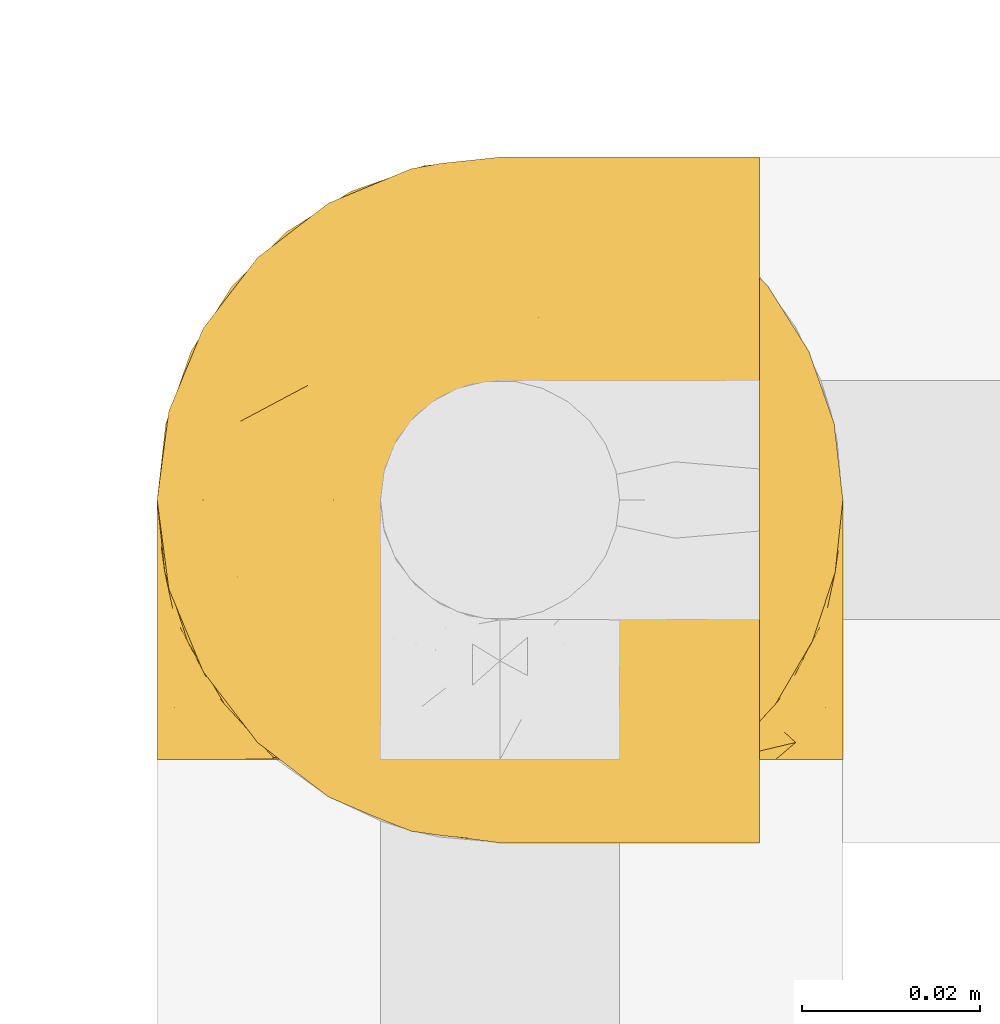
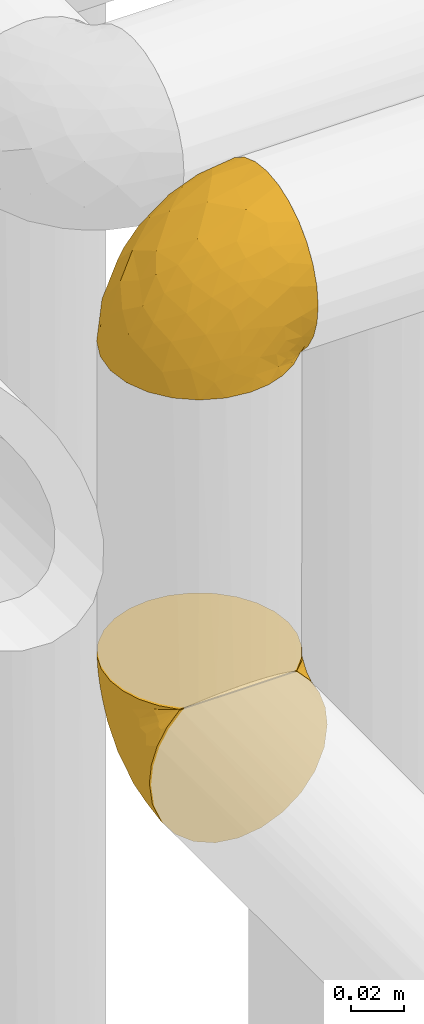
# One storey, part 295 of 827: 2 coverings.
"""IFC2X3 building model written with IfcOpenShell, lengths in millimetres."""

from ifc_helpers import new_model, entity, si_unit, converted_unit, derived_unit, direction, frame, origin, place, context, subcontext, project, spatial, faceted_brep, element, save


model = new_model("IFC2X3")

# Units and contexts
model_context = context("Model", 3, precision=0.01, world=origin(), true_north=direction((6.12303176911189e-17, 1.0)))
body_context = subcontext(model_context, "Body", "Model", "MODEL_VIEW")
ifc_project = project(units=[si_unit("LENGTHUNIT", "METRE", prefix="MILLI"), si_unit("AREAUNIT", "SQUARE_METRE"), si_unit("VOLUMEUNIT", "CUBIC_METRE"), converted_unit("PLANEANGLEUNIT", "DEGREE", entity("IfcRatioMeasure", 0.0174532925199433), si_unit("PLANEANGLEUNIT", "RADIAN"), dimensions=[0, 0, 0, 0, 0, 0, 0]), si_unit("MASSUNIT", "GRAM", prefix="KILO"), derived_unit("MASSDENSITYUNIT", [(si_unit("MASSUNIT", "GRAM", prefix="KILO"), 1), (si_unit("LENGTHUNIT", "METRE"), -3)]), derived_unit("MOMENTOFINERTIAUNIT", [(si_unit("LENGTHUNIT", "METRE"), 4)]), si_unit("TIMEUNIT", "SECOND"), si_unit("FREQUENCYUNIT", "HERTZ"), si_unit("THERMODYNAMICTEMPERATUREUNIT", "DEGREE_CELSIUS"), derived_unit("THERMALTRANSMITTANCEUNIT", [(si_unit("MASSUNIT", "GRAM", prefix="KILO"), 1), (si_unit("THERMODYNAMICTEMPERATUREUNIT", "KELVIN"), -1), (si_unit("TIMEUNIT", "SECOND"), -3)]), derived_unit("VOLUMETRICFLOWRATEUNIT", [(si_unit("LENGTHUNIT", "METRE"), 3), (si_unit("TIMEUNIT", "SECOND"), -1)]), derived_unit("MASSFLOWRATEUNIT", [(si_unit("MASSUNIT", "GRAM", prefix="KILO"), 1), (si_unit("TIMEUNIT", "SECOND"), -1)]), derived_unit("ROTATIONALFREQUENCYUNIT", [(si_unit("TIMEUNIT", "SECOND"), -1)]), si_unit("ELECTRICCURRENTUNIT", "AMPERE"), si_unit("ELECTRICVOLTAGEUNIT", "VOLT"), si_unit("POWERUNIT", "WATT"), si_unit("FORCEUNIT", "NEWTON", prefix="KILO"), si_unit("ILLUMINANCEUNIT", "LUX"), si_unit("LUMINOUSFLUXUNIT", "LUMEN"), si_unit("LUMINOUSINTENSITYUNIT", "CANDELA"), derived_unit("USERDEFINED", [(si_unit("MASSUNIT", "GRAM", prefix="KILO"), -1), (si_unit("LENGTHUNIT", "METRE"), -2), (si_unit("TIMEUNIT", "SECOND"), 3), (si_unit("LUMINOUSFLUXUNIT", "LUMEN"), 1)]), derived_unit("LINEARVELOCITYUNIT", [(si_unit("LENGTHUNIT", "METRE"), 1), (si_unit("TIMEUNIT", "SECOND"), -1)]), si_unit("PRESSUREUNIT", "PASCAL"), derived_unit("USERDEFINED", [(si_unit("LENGTHUNIT", "METRE"), -2), (si_unit("MASSUNIT", "GRAM", prefix="KILO"), 1), (si_unit("TIMEUNIT", "SECOND"), -2)]), derived_unit("LINEARFORCEUNIT", [(si_unit("MASSUNIT", "GRAM", prefix="KILO"), 1), (si_unit("LENGTHUNIT", "METRE"), 1), (si_unit("TIMEUNIT", "SECOND"), -2), (si_unit("LENGTHUNIT", "METRE"), -1)]), derived_unit("PLANARFORCEUNIT", [(si_unit("MASSUNIT", "GRAM", prefix="KILO"), 1), (si_unit("LENGTHUNIT", "METRE"), 1), (si_unit("TIMEUNIT", "SECOND"), -2), (si_unit("LENGTHUNIT", "METRE"), -2)])], contexts=[model_context])

# Site, building, storey
site_placement = place(None, origin())
site = spatial("IfcSite", under=ifc_project, at=site_placement, CompositionType="ELEMENT")
building_placement = place(site_placement, origin())
building = spatial("IfcBuilding", under=site, at=building_placement, CompositionType="ELEMENT")
storey_placement = place(building_placement, frame((0.0, 0.0, 28200.0)))
storey = spatial("IfcBuildingStorey", under=building, at=storey_placement, Name="08", CompositionType="ELEMENT", Elevation=28200.0)

# Coverings
covering_1_placement = place(storey_placement, frame((34787.8, 15358.9, 2759.95)))
element("IfcCovering", 1, at=covering_1_placement, inside=storey, Name=":ADSK_", ObjectType=":ADSK_", PredefinedType="INSULATION", context=body_context, shape_type="Brep", body=[
    faceted_brep([(74.68, 47.38, 69.15), (70.1, 54.67, 69.15), (64.01, 60.76, 69.15), (56.72, 65.34, 69.15), (48.6, 68.18, 69.15), (40.05, 69.15, 69.15), (31.49, 68.18, 69.15), (23.36, 65.33, 69.15), (16.07, 60.75, 69.15), (9.98, 54.66, 69.15), (5.4, 47.37, 69.15), (2.56, 39.25, 69.15), (1.6, 30.7, 69.15), (2.46, 22.59, 69.15), (5.01, 14.86, 69.15), (9.13, 7.84, 69.15), (14.62, 1.85, 69.15), (16.82, 1.85, 69.15), (18.56, 1.85, 69.15), (20.52, 1.85, 69.15), (22.49, 1.85, 69.15), (24.46, 1.85, 69.15), (26.42, 1.85, 69.15), (28.39, 1.85, 69.15), (30.36, 1.85, 69.15), (32.55, 1.85, 69.15), (34.75, 1.85, 69.15), (36.94, 1.85, 69.15), (39.13, 1.85, 69.15), (41.33, 1.85, 69.15), (43.52, 1.85, 69.15), (45.72, 1.85, 69.15), (47.91, 1.85, 69.15), (50.11, 1.85, 69.15), (52.3, 1.85, 69.15), (54.49, 1.85, 69.15), (56.69, 1.85, 69.15), (58.88, 1.85, 69.15), (61.08, 1.85, 69.15), (63.27, 1.85, 69.15), (65.47, 1.85, 69.15), (70.97, 7.85, 69.15), (75.09, 14.88, 69.15), (77.64, 22.61, 69.15), (78.5, 30.7, 69.15), (77.53, 39.26, 69.15), (14.62, 1.6, 68.89), (9.12, 1.6, 62.89), (5.0, 1.6, 55.87), (2.46, 1.6, 48.14), (1.6, 1.6, 40.05), (2.91, 1.6, 30.09), (6.75, 1.6, 20.82), (12.86, 1.6, 12.86), (20.82, 1.6, 6.75), (30.09, 1.6, 2.91), (40.05, 1.6, 1.6), (50.0, 1.6, 2.91), (59.27, 1.6, 6.75), (67.23, 1.6, 12.86), (73.34, 1.6, 20.82), (77.19, 1.6, 30.09), (78.5, 1.6, 40.05), (77.63, 1.6, 48.14), (75.09, 1.6, 55.87), (70.97, 1.6, 62.89), (65.47, 1.6, 68.89), (63.27, 1.6, 68.89), (62.29, 1.6, 68.89), (60.7, 1.6, 68.89), (59.11, 1.6, 68.89), (57.52, 1.6, 68.89), (55.93, 1.6, 68.89), (54.34, 1.6, 68.89), (52.76, 1.6, 68.89), (51.17, 1.6, 68.89), (49.58, 1.6, 68.89), (47.99, 1.6, 68.89), (46.4, 1.6, 68.89), (44.81, 1.6, 68.89), (43.22, 1.6, 68.89), (41.63, 1.6, 68.89), (40.05, 1.6, 68.89), (38.46, 1.6, 68.89), (36.87, 1.6, 68.89), (35.28, 1.6, 68.89), (33.69, 1.6, 68.89), (32.1, 1.6, 68.89), (30.51, 1.6, 68.89), (28.92, 1.6, 68.89), (27.33, 1.6, 68.89), (25.37, 1.6, 68.89), (23.4, 1.6, 68.89), (21.21, 1.6, 68.89), (19.01, 1.6, 68.89), (16.82, 1.6, 68.89), (42.32, 1.78, 68.97), (44.02, 1.77, 68.96), (47.13, 1.78, 68.97), (48.74, 1.77, 68.97), (23.57, 1.79, 68.98), (25.13, 1.78, 68.97), (61.34, 1.76, 68.96), (22.02, 1.77, 68.96), (29.72, 1.77, 68.96), (56.73, 1.76, 68.96), (55.14, 1.77, 68.96), (37.66, 1.77, 68.96), (64.12, 1.8, 69.0), (28.13, 1.76, 68.96), (26.62, 1.77, 68.96), (31.46, 1.78, 68.97), (16.16, 1.77, 68.96), (39.16, 1.77, 68.96), (50.37, 1.76, 68.96), (17.69, 1.77, 68.97), (19.17, 1.78, 68.97), (62.78, 1.77, 68.97), (58.35, 1.77, 68.96), (45.53, 1.77, 68.96), (59.91, 1.78, 68.97), (65.47, 1.77, 68.97), (65.47, 1.8, 69.02), (65.47, 1.82, 69.08), (14.62, 1.77, 68.97), (14.62, 1.72, 68.94), (14.62, 1.66, 68.92), (20.59, 1.76, 68.96), (32.99, 1.77, 68.96), (34.48, 1.76, 68.95), (51.91, 1.77, 68.96), (65.47, 1.66, 68.92), (65.47, 1.72, 68.94), (53.48, 1.78, 68.98), (14.62, 1.82, 69.08), (14.62, 1.8, 69.02), (40.77, 1.77, 68.96), (35.97, 1.78, 68.97), (7.84, 3.72, 61.33), (3.53, 7.41, 53.1), (8.32, 6.13, 63.33), (1.6, 21.47, 49.27), (2.19, 19.34, 55.53), (1.6, 26.8, 54.6), (1.6, 8.87, 41.99), (4.57, 9.2, 57.07), (3.96, 12.79, 57.95), (2.28, 14.62, 51.56), (1.6, 7.34, 41.58), (7.69, 5.33, 61.7), (3.53, 17.64, 63.33), (8.32, 7.7, 65.0), (7.84, 9.41, 67.02), (1.6, 28.75, 61.87), (1.6, 16.15, 43.94), (4.34, 14.14, 61.21), (1.6, 29.16, 63.4), (29.63, 57.02, 33.11), (27.34, 64.92, 52.82), (40.05, 64.0, 43.3), (2.39, 11.92, 33.73), (2.43, 19.16, 36.52), (9.07, 28.65, 24.87), (16.64, 24.62, 14.17), (9.54, 15.19, 18.43), (4.52, 18.36, 28.67), (4.52, 9.2, 26.0), (7.49, 46.98, 49.25), (7.49, 50.24, 59.72), (12.85, 56.1, 55.1), (2.35, 28.97, 44.72), (22.66, 54.46, 34.15), (32.9, 21.34, 5.25), (25.33, 18.4, 6.75), (40.05, 66.44, 55.54), (16.64, 12.07, 10.47), (19.99, 45.49, 25.49), (16.37, 50.57, 35.53), (3.26, 36.04, 48.22), (3.75, 42.07, 58.71), (19.58, 62.12, 57.42), (7.5, 37.37, 34.84), (4.04, 29.39, 36.87), (13.94, 53.59, 45.01), (19.58, 58.06, 44.4), (28.21, 49.27, 23.96), (24.75, 29.63, 11.2), (31.42, 33.21, 10.56), (26.2, 40.1, 16.81), (33.36, 44.08, 17.38), (40.05, 49.36, 21.38), (40.05, 56.68, 32.34), (40.05, 15.2, 4.3), (16.14, 35.57, 20.65), (12.85, 41.7, 29.66), (10.47, 46.4, 39.6), (6.49, 41.41, 42.55), (40.05, 27.45, 6.74), (40.05, 38.4, 14.06), (75.57, 12.99, 26.84), (47.37, 21.33, 5.28), (52.91, 42.89, 18.52), (50.46, 57.04, 33.13), (67.23, 56.11, 55.1), (60.5, 62.13, 57.43), (70.55, 21.89, 20.72), (63.45, 16.62, 11.46), (62.61, 32.9, 17.69), (72.6, 46.99, 49.26), (72.6, 50.25, 59.73), (76.34, 42.08, 58.71), (59.34, 49.91, 29.72), (77.76, 15.6, 35.35), (78.5, 16.15, 43.94), (78.5, 8.87, 41.99), (78.5, 29.16, 63.4), (53.16, 13.16, 4.93), (70.55, 10.83, 17.46), (48.88, 33.8, 10.94), (54.76, 25.02, 8.92), (52.74, 64.92, 52.83), (71.93, 32.83, 29.34), (75.79, 20.56, 30.26), (60.5, 58.07, 44.4), (77.86, 21.46, 39.06), (77.64, 28.1, 43.06), (78.5, 26.8, 54.6), (78.5, 21.47, 49.27), (67.23, 51.29, 42.69), (76.82, 36.04, 48.2), (78.5, 28.75, 61.87), (77.8, 8.45, 33.44), (67.23, 41.73, 29.67), (73.2, 39.27, 38.5), (67.66, 33.56, 23.35), (75.99, 27.29, 34.97), (76.57, 7.41, 53.1), (73.21, 3.51, 59.68), (71.93, 4.68, 62.19), (71.07, 5.52, 64.11), (75.09, 8.75, 57.97), (76.13, 12.79, 57.95), (76.57, 17.65, 63.33), (77.69, 13.9, 51.77), (72.26, 9.42, 67.02), (71.77, 7.68, 64.98), (77.9, 19.33, 55.53), (75.75, 14.13, 61.22)], [[[0, 1, 2, 3, 4, 5, 6, 7, 8, 9, 10, 11, 12, 13, 14, 15, 16, 17, 18, 19, 20, 21, 22, 23, 24, 25, 26, 27, 28, 29, 30, 31, 32, 33, 34, 35, 36, 37, 38, 39, 40, 41, 42, 43, 44, 45]], [[46, 47, 48, 49, 50, 51, 52, 53, 54, 55, 56, 57, 58, 59, 60, 61, 62, 63, 64, 65, 66, 67, 68, 69, 70, 71, 72, 73, 74, 75, 76, 77, 78, 79, 80, 81, 82, 83, 84, 85, 86, 87, 88, 89, 90, 91, 92, 93, 94, 95]], [[96, 97, 30]], [[98, 77, 99]], [[100, 101, 21]], [[69, 68, 102]], [[20, 19, 103]], [[24, 23, 104]], [[20, 103, 100]], [[72, 105, 106]], [[84, 83, 107]], [[89, 88, 104]], [[108, 67, 66]], [[109, 110, 90]], [[111, 25, 24]], [[112, 17, 16]], [[82, 113, 83]], [[109, 23, 22]], [[114, 76, 75]], [[105, 36, 106]], [[104, 111, 24]], [[18, 115, 116]], [[97, 96, 80]], [[67, 108, 117]], [[105, 71, 118]], [[31, 97, 119]], [[102, 120, 69]], [[108, 121, 122, 123, 40]], [[112, 95, 115]], [[17, 115, 18]], [[94, 116, 115]], [[117, 68, 67]], [[38, 117, 39]], [[112, 124, 125, 126, 46]], [[17, 112, 115]], [[70, 120, 118]], [[39, 117, 108]], [[120, 38, 37]], [[120, 37, 118]], [[120, 70, 69]], [[116, 94, 127]], [[128, 86, 129]], [[117, 38, 102]], [[74, 130, 75]], [[99, 33, 32]], [[115, 95, 94]], [[39, 108, 40]], [[108, 66, 131, 132, 121]], [[105, 72, 71]], [[118, 37, 36]], [[71, 70, 118]], [[35, 106, 36]], [[36, 105, 118]], [[35, 133, 106]], [[74, 73, 133]], [[106, 133, 73]], [[99, 114, 33]], [[133, 35, 34]], [[73, 72, 106]], [[95, 112, 46]], [[112, 16, 134, 135, 124]], [[130, 114, 75]], [[99, 76, 114]], [[114, 130, 33]], [[34, 33, 130]], [[78, 77, 98]], [[98, 119, 78]], [[130, 133, 34]], [[133, 130, 74]], [[79, 97, 80]], [[98, 99, 32]], [[98, 32, 31]], [[77, 76, 99]], [[97, 79, 119]], [[136, 96, 29]], [[30, 97, 31]], [[136, 29, 28]], [[81, 80, 96]], [[29, 96, 30]], [[31, 119, 98]], [[119, 79, 78]], [[96, 136, 81]], [[82, 81, 136]], [[113, 107, 83]], [[84, 107, 137]], [[107, 27, 137]], [[113, 28, 107]], [[27, 107, 28]], [[85, 84, 137]], [[137, 27, 26]], [[113, 136, 28]], [[136, 113, 82]], [[109, 89, 104]], [[86, 85, 129]], [[89, 109, 90]], [[111, 87, 128]], [[26, 129, 137]], [[88, 111, 104]], [[25, 111, 128]], [[22, 110, 109]], [[23, 109, 104]], [[110, 91, 90]], [[100, 92, 101]], [[110, 22, 101]], [[91, 110, 101]], [[116, 19, 18]], [[111, 88, 87]], [[127, 103, 19]], [[25, 128, 26]], [[86, 128, 87]], [[128, 129, 26]], [[137, 129, 85]], [[120, 102, 38]], [[117, 102, 68]], [[91, 101, 92]], [[21, 101, 22]], [[93, 92, 103]], [[100, 21, 20]], [[100, 103, 92]], [[127, 93, 103]], [[93, 127, 94]], [[116, 127, 19]], [[126, 138, 47]], [[48, 138, 139]], [[140, 125, 124]], [[141, 142, 143]], [[144, 49, 139]], [[145, 140, 146]], [[48, 139, 49]], [[139, 145, 147]], [[49, 144, 148, 50]], [[126, 125, 149]], [[14, 13, 150]], [[151, 146, 140]], [[149, 140, 145]], [[152, 151, 135]], [[152, 14, 150]], [[16, 15, 134]], [[13, 153, 150]], [[124, 151, 140]], [[141, 147, 142]], [[14, 152, 15]], [[15, 152, 134]], [[47, 46, 126]], [[139, 154, 144]], [[138, 48, 47]], [[125, 140, 149]], [[135, 134, 152]], [[146, 155, 142]], [[145, 146, 147]], [[149, 139, 138]], [[147, 141, 154]], [[147, 146, 142]], [[139, 147, 154]], [[139, 149, 145]], [[149, 138, 126]], [[155, 146, 151]], [[150, 143, 142]], [[152, 155, 151]], [[150, 142, 155]], [[13, 12, 156, 153]], [[153, 143, 150]], [[152, 150, 155]], [[151, 124, 135]], [[157, 158, 159]], [[160, 154, 161]], [[162, 163, 164]], [[165, 166, 160]], [[167, 168, 169]], [[141, 170, 161]], [[156, 12, 11]], [[158, 157, 171]], [[172, 55, 173]], [[158, 6, 174]], [[175, 54, 53]], [[52, 166, 164]], [[52, 164, 53]], [[54, 175, 173]], [[166, 52, 51]], [[176, 177, 171]], [[178, 143, 179]], [[156, 11, 179]], [[8, 7, 180]], [[169, 9, 8]], [[179, 143, 153, 156]], [[179, 11, 10]], [[168, 179, 10]], [[181, 162, 182]], [[179, 167, 178]], [[183, 184, 177]], [[183, 169, 184]], [[176, 171, 185]], [[172, 186, 187]], [[158, 7, 6]], [[159, 158, 174]], [[184, 180, 158]], [[54, 173, 55]], [[180, 169, 8]], [[188, 189, 187]], [[9, 168, 10]], [[186, 188, 187]], [[190, 157, 159, 191]], [[55, 172, 192]], [[176, 193, 194]], [[161, 170, 182]], [[162, 164, 165]], [[175, 164, 163]], [[51, 50, 148]], [[167, 195, 196]], [[178, 182, 170]], [[6, 5, 174]], [[158, 180, 7]], [[169, 180, 184]], [[169, 168, 9]], [[179, 168, 167]], [[182, 162, 165]], [[162, 194, 193]], [[161, 165, 160]], [[195, 181, 196]], [[192, 172, 197]], [[192, 56, 55]], [[189, 190, 198]], [[198, 197, 187]], [[172, 187, 197]], [[185, 189, 188]], [[198, 187, 189]], [[186, 172, 173]], [[173, 163, 186]], [[193, 186, 163]], [[176, 185, 188]], [[185, 157, 190]], [[188, 186, 193]], [[177, 176, 194]], [[188, 193, 176]], [[162, 193, 163]], [[195, 177, 194]], [[171, 177, 184]], [[181, 195, 194]], [[183, 167, 169]], [[162, 181, 194]], [[196, 182, 178]], [[158, 171, 184]], [[171, 157, 185]], [[177, 195, 183]], [[167, 183, 195]], [[182, 196, 181]], [[178, 170, 143]], [[178, 167, 196]], [[164, 175, 53]], [[173, 175, 163]], [[160, 51, 148]], [[164, 166, 165]], [[51, 160, 166]], [[160, 148, 144, 154]], [[141, 161, 154]], [[182, 165, 161]], [[190, 189, 185]], [[143, 170, 141]], [[60, 199, 61]], [[197, 200, 192]], [[201, 190, 202]], [[200, 57, 192]], [[203, 204, 2]], [[205, 206, 207]], [[208, 209, 210]], [[211, 207, 201]], [[212, 213, 214]], [[45, 215, 210]], [[216, 206, 58]], [[45, 44, 215]], [[59, 217, 60]], [[60, 217, 199]], [[0, 45, 210]], [[218, 201, 219]], [[202, 159, 220]], [[205, 221, 222]], [[223, 204, 203]], [[1, 203, 2]], [[57, 200, 216]], [[220, 3, 204]], [[220, 174, 4]], [[1, 0, 209]], [[212, 224, 213]], [[225, 226, 227]], [[228, 223, 203]], [[208, 210, 229]], [[210, 226, 229]], [[3, 220, 4]], [[58, 206, 59]], [[209, 203, 1]], [[202, 220, 223]], [[228, 203, 208]], [[202, 211, 201]], [[3, 2, 204]], [[202, 190, 191, 159]], [[210, 215, 230, 226]], [[199, 212, 231]], [[232, 233, 221]], [[233, 208, 229]], [[207, 206, 219]], [[217, 206, 205]], [[227, 224, 225]], [[233, 232, 228]], [[201, 207, 219]], [[234, 232, 221]], [[218, 219, 200]], [[202, 223, 211]], [[174, 220, 159]], [[174, 5, 4]], [[61, 231, 62]], [[220, 204, 223]], [[210, 209, 0]], [[203, 209, 208]], [[225, 233, 229]], [[224, 227, 213]], [[221, 233, 235]], [[57, 56, 192]], [[198, 218, 197]], [[200, 219, 216]], [[201, 198, 190]], [[197, 218, 200]], [[198, 201, 218]], [[206, 216, 219]], [[58, 57, 216]], [[231, 212, 214]], [[222, 212, 199]], [[228, 211, 223]], [[207, 211, 232]], [[62, 231, 214]], [[199, 231, 61]], [[233, 228, 208]], [[211, 228, 232]], [[222, 221, 235]], [[234, 205, 207]], [[206, 217, 59]], [[199, 217, 205]], [[205, 222, 199]], [[224, 222, 235]], [[222, 224, 212]], [[224, 235, 225]], [[233, 225, 235]], [[226, 225, 229]], [[205, 234, 221]], [[207, 232, 234]], [[63, 214, 236]], [[214, 213, 236]], [[214, 63, 62]], [[237, 236, 238]], [[238, 132, 131]], [[236, 237, 64]], [[239, 240, 241]], [[63, 236, 64]], [[131, 66, 65]], [[237, 131, 65]], [[242, 230, 43]], [[237, 65, 64]], [[239, 121, 132]], [[42, 242, 43]], [[241, 240, 243]], [[41, 123, 244]], [[43, 230, 215, 44]], [[244, 122, 245]], [[227, 246, 243]], [[241, 247, 245]], [[121, 239, 245]], [[41, 40, 123]], [[132, 238, 239]], [[244, 42, 41]], [[131, 237, 238]], [[240, 239, 238]], [[245, 239, 241]], [[247, 241, 246]], [[247, 244, 245]], [[238, 236, 240]], [[243, 236, 213]], [[236, 243, 240]], [[227, 226, 246]], [[243, 213, 227]], [[242, 246, 226]], [[243, 246, 241]], [[246, 242, 247]], [[244, 247, 242]], [[242, 226, 230]], [[42, 244, 242]], [[122, 244, 123]], [[122, 121, 245]]]),
])
covering_2_placement = place(storey_placement, frame((34787.8, 15349.55, 2969.3)))
element("IfcCovering", 2, at=covering_2_placement, inside=storey, Name=":ADSK_", ObjectType=":ADSK_", PredefinedType="INSULATION", context=body_context, shape_type="Brep", body=[
    faceted_brep([(69.15, 74.68, 47.38), (69.15, 70.1, 54.67), (69.15, 64.01, 60.76), (69.15, 56.72, 65.34), (69.15, 48.6, 68.18), (69.15, 40.05, 69.15), (69.15, 31.49, 68.18), (69.15, 23.36, 65.33), (69.15, 16.07, 60.75), (69.15, 9.98, 54.66), (69.15, 5.4, 47.37), (69.15, 2.56, 39.25), (69.15, 1.6, 30.7), (69.15, 2.46, 22.59), (69.15, 5.01, 14.86), (69.15, 9.13, 7.84), (69.15, 14.62, 1.85), (69.15, 16.82, 1.85), (69.15, 18.56, 1.85), (69.15, 20.52, 1.85), (69.15, 22.49, 1.85), (69.15, 24.46, 1.85), (69.15, 26.42, 1.85), (69.15, 28.39, 1.85), (69.15, 30.36, 1.85), (69.15, 32.55, 1.85), (69.15, 34.75, 1.85), (69.15, 36.94, 1.85), (69.15, 39.13, 1.85), (69.15, 41.33, 1.85), (69.15, 43.52, 1.85), (69.15, 45.72, 1.85), (69.15, 47.91, 1.85), (69.15, 50.11, 1.85), (69.15, 52.3, 1.85), (69.15, 54.49, 1.85), (69.15, 56.69, 1.85), (69.15, 58.88, 1.85), (69.15, 61.08, 1.85), (69.15, 63.27, 1.85), (69.15, 65.47, 1.85), (69.15, 70.97, 7.85), (69.15, 75.09, 14.88), (69.15, 77.64, 22.61), (69.15, 78.5, 30.7), (69.15, 77.53, 39.26), (68.89, 14.62, 1.6), (62.89, 9.12, 1.6), (55.87, 5.0, 1.6), (48.14, 2.46, 1.6), (40.05, 1.6, 1.6), (30.09, 2.91, 1.6), (20.82, 6.75, 1.6), (12.86, 12.86, 1.6), (6.75, 20.82, 1.6), (2.91, 30.09, 1.6), (1.6, 40.05, 1.6), (2.91, 50.0, 1.6), (6.75, 59.27, 1.6), (12.86, 67.23, 1.6), (20.82, 73.34, 1.6), (30.09, 77.19, 1.6), (40.05, 78.5, 1.6), (48.14, 77.63, 1.6), (55.87, 75.09, 1.6), (62.89, 70.97, 1.6), (68.89, 65.47, 1.6), (68.89, 63.27, 1.6), (68.89, 62.29, 1.6), (68.89, 60.7, 1.6), (68.89, 59.11, 1.6), (68.89, 57.52, 1.6), (68.89, 55.93, 1.6), (68.89, 54.34, 1.6), (68.89, 52.76, 1.6), (68.89, 51.17, 1.6), (68.89, 49.58, 1.6), (68.89, 47.99, 1.6), (68.89, 46.4, 1.6), (68.89, 44.81, 1.6), (68.89, 43.22, 1.6), (68.89, 41.63, 1.6), (68.89, 40.05, 1.6), (68.89, 38.46, 1.6), (68.89, 36.87, 1.6), (68.89, 35.28, 1.6), (68.89, 33.69, 1.6), (68.89, 32.1, 1.6), (68.89, 30.51, 1.6), (68.89, 28.92, 1.6), (68.89, 27.33, 1.6), (68.89, 25.37, 1.6), (68.89, 23.4, 1.6), (68.89, 21.21, 1.6), (68.89, 19.01, 1.6), (68.89, 16.82, 1.6), (68.97, 42.32, 1.78), (68.96, 44.02, 1.77), (68.97, 47.13, 1.78), (68.97, 48.74, 1.77), (68.98, 23.57, 1.79), (68.97, 25.13, 1.78), (68.96, 61.34, 1.76), (68.96, 22.02, 1.77), (68.96, 29.72, 1.77), (68.96, 56.73, 1.76), (68.96, 55.14, 1.77), (68.96, 37.66, 1.77), (69.0, 64.12, 1.8), (68.96, 28.13, 1.76), (68.96, 26.62, 1.77), (68.97, 31.46, 1.78), (68.96, 16.16, 1.77), (68.96, 39.16, 1.77), (68.96, 50.37, 1.76), (68.97, 17.69, 1.77), (68.97, 19.17, 1.78), (68.97, 62.78, 1.77), (68.96, 58.35, 1.77), (68.96, 45.53, 1.77), (68.97, 59.91, 1.78), (68.97, 65.47, 1.77), (69.02, 65.47, 1.8), (69.08, 65.47, 1.82), (68.97, 14.62, 1.77), (68.94, 14.62, 1.72), (68.92, 14.62, 1.66), (68.96, 20.59, 1.76), (68.96, 32.99, 1.77), (68.95, 34.48, 1.76), (68.96, 51.91, 1.77), (68.92, 65.47, 1.66), (68.94, 65.47, 1.72), (68.98, 53.48, 1.78), (69.08, 14.62, 1.82), (69.02, 14.62, 1.8), (68.96, 40.77, 1.77), (68.97, 35.97, 1.78), (61.33, 7.84, 3.72), (53.1, 3.53, 7.41), (63.33, 8.32, 6.13), (55.53, 2.19, 19.34), (63.33, 3.53, 17.64), (54.6, 1.6, 26.8), (41.99, 1.6, 8.87), (57.07, 4.57, 9.2), (57.95, 3.96, 12.79), (51.56, 2.28, 14.62), (41.58, 1.6, 7.34), (61.7, 7.69, 5.33), (65.0, 8.32, 7.7), (67.02, 7.84, 9.41), (61.87, 1.6, 28.75), (49.27, 1.6, 21.47), (43.94, 1.6, 16.15), (61.21, 4.34, 14.14), (63.4, 1.6, 29.16), (33.11, 29.63, 57.02), (52.82, 27.34, 64.92), (43.3, 40.05, 64.0), (33.73, 2.39, 11.92), (36.52, 2.43, 19.16), (24.87, 9.07, 28.65), (14.17, 16.64, 24.62), (18.43, 9.54, 15.19), (28.67, 4.52, 18.36), (26.0, 4.52, 9.2), (49.25, 7.49, 46.98), (59.72, 7.49, 50.24), (55.1, 12.85, 56.1), (44.72, 2.35, 28.97), (34.15, 22.66, 54.46), (5.25, 32.9, 21.34), (6.75, 25.33, 18.4), (55.54, 40.05, 66.44), (10.47, 16.64, 12.07), (25.49, 19.99, 45.49), (35.53, 16.37, 50.57), (48.22, 3.26, 36.04), (58.71, 3.75, 42.07), (57.42, 19.58, 62.12), (34.84, 7.5, 37.37), (36.87, 4.04, 29.39), (45.01, 13.94, 53.59), (44.4, 19.58, 58.06), (23.96, 28.21, 49.27), (11.2, 24.75, 29.63), (10.56, 31.42, 33.21), (16.81, 26.2, 40.1), (17.38, 33.36, 44.08), (21.38, 40.05, 49.36), (32.34, 40.05, 56.68), (4.3, 40.05, 15.2), (20.65, 16.14, 35.57), (29.66, 12.85, 41.7), (39.6, 10.47, 46.4), (42.55, 6.49, 41.41), (6.74, 40.05, 27.45), (14.06, 40.05, 38.4), (26.84, 75.57, 12.99), (5.28, 47.37, 21.33), (18.52, 52.91, 42.89), (33.13, 50.46, 57.04), (55.1, 67.23, 56.11), (57.43, 60.5, 62.13), (20.72, 70.55, 21.89), (11.46, 63.45, 16.62), (17.69, 62.61, 32.9), (49.26, 72.6, 46.99), (59.73, 72.6, 50.25), (58.71, 76.34, 42.08), (29.72, 59.34, 49.91), (35.35, 77.76, 15.6), (43.94, 78.5, 16.15), (41.99, 78.5, 8.87), (63.4, 78.5, 29.16), (4.93, 53.16, 13.16), (17.46, 70.55, 10.83), (10.94, 48.88, 33.8), (8.92, 54.76, 25.02), (52.83, 52.74, 64.92), (29.34, 71.93, 32.83), (30.26, 75.79, 20.56), (44.4, 60.5, 58.07), (39.06, 77.86, 21.46), (43.06, 77.64, 28.1), (54.6, 78.5, 26.8), (49.27, 78.5, 21.47), (42.69, 67.23, 51.29), (48.2, 76.82, 36.04), (61.87, 78.5, 28.75), (33.44, 77.8, 8.45), (29.67, 67.23, 41.73), (38.5, 73.2, 39.27), (23.35, 67.66, 33.56), (34.97, 75.99, 27.29), (53.1, 76.57, 7.41), (59.68, 73.21, 3.51), (62.19, 71.93, 4.68), (64.11, 71.07, 5.52), (57.97, 75.09, 8.75), (57.95, 76.13, 12.79), (63.33, 76.57, 17.65), (51.77, 77.69, 13.9), (67.02, 72.26, 9.42), (64.98, 71.77, 7.68), (55.53, 77.9, 19.33), (61.22, 75.75, 14.13)], [[[0, 1, 2, 3, 4, 5, 6, 7, 8, 9, 10, 11, 12, 13, 14, 15, 16, 17, 18, 19, 20, 21, 22, 23, 24, 25, 26, 27, 28, 29, 30, 31, 32, 33, 34, 35, 36, 37, 38, 39, 40, 41, 42, 43, 44, 45]], [[46, 47, 48, 49, 50, 51, 52, 53, 54, 55, 56, 57, 58, 59, 60, 61, 62, 63, 64, 65, 66, 67, 68, 69, 70, 71, 72, 73, 74, 75, 76, 77, 78, 79, 80, 81, 82, 83, 84, 85, 86, 87, 88, 89, 90, 91, 92, 93, 94, 95]], [[96, 97, 30]], [[98, 77, 99]], [[100, 101, 21]], [[69, 68, 102]], [[20, 19, 103]], [[24, 23, 104]], [[20, 103, 100]], [[72, 105, 106]], [[84, 83, 107]], [[89, 88, 104]], [[108, 67, 66]], [[109, 110, 90]], [[111, 25, 24]], [[112, 17, 16]], [[82, 113, 83]], [[109, 23, 22]], [[114, 76, 75]], [[105, 36, 106]], [[104, 111, 24]], [[18, 115, 116]], [[97, 96, 80]], [[67, 108, 117]], [[105, 71, 118]], [[31, 97, 119]], [[102, 120, 69]], [[108, 121, 122, 123, 40]], [[112, 95, 115]], [[17, 115, 18]], [[94, 116, 115]], [[117, 68, 67]], [[38, 117, 39]], [[112, 124, 125, 126, 46]], [[17, 112, 115]], [[70, 120, 118]], [[39, 117, 108]], [[120, 38, 37]], [[120, 37, 118]], [[120, 70, 69]], [[116, 94, 127]], [[128, 86, 129]], [[117, 38, 102]], [[74, 130, 75]], [[99, 33, 32]], [[115, 95, 94]], [[39, 108, 40]], [[108, 66, 131, 132, 121]], [[105, 72, 71]], [[118, 37, 36]], [[71, 70, 118]], [[35, 106, 36]], [[36, 105, 118]], [[35, 133, 106]], [[74, 73, 133]], [[106, 133, 73]], [[99, 114, 33]], [[133, 35, 34]], [[73, 72, 106]], [[95, 112, 46]], [[112, 16, 134, 135, 124]], [[130, 114, 75]], [[99, 76, 114]], [[114, 130, 33]], [[34, 33, 130]], [[78, 77, 98]], [[98, 119, 78]], [[130, 133, 34]], [[133, 130, 74]], [[79, 97, 80]], [[98, 99, 32]], [[98, 32, 31]], [[77, 76, 99]], [[97, 79, 119]], [[136, 96, 29]], [[30, 97, 31]], [[136, 29, 28]], [[81, 80, 96]], [[29, 96, 30]], [[31, 119, 98]], [[119, 79, 78]], [[96, 136, 81]], [[82, 81, 136]], [[113, 107, 83]], [[84, 107, 137]], [[107, 27, 137]], [[113, 28, 107]], [[27, 107, 28]], [[85, 84, 137]], [[137, 27, 26]], [[113, 136, 28]], [[136, 113, 82]], [[109, 89, 104]], [[86, 85, 129]], [[89, 109, 90]], [[111, 87, 128]], [[26, 129, 137]], [[88, 111, 104]], [[25, 111, 128]], [[22, 110, 109]], [[23, 109, 104]], [[110, 91, 90]], [[100, 92, 101]], [[110, 22, 101]], [[91, 110, 101]], [[116, 19, 18]], [[111, 88, 87]], [[127, 103, 19]], [[25, 128, 26]], [[86, 128, 87]], [[128, 129, 26]], [[137, 129, 85]], [[120, 102, 38]], [[117, 102, 68]], [[91, 101, 92]], [[21, 101, 22]], [[93, 92, 103]], [[100, 21, 20]], [[100, 103, 92]], [[127, 93, 103]], [[93, 127, 94]], [[116, 127, 19]], [[126, 138, 47]], [[48, 138, 139]], [[140, 125, 124]], [[141, 142, 143]], [[144, 49, 139]], [[145, 140, 146]], [[48, 139, 49]], [[139, 145, 147]], [[49, 144, 148, 50]], [[126, 125, 149]], [[14, 13, 142]], [[150, 146, 140]], [[149, 140, 145]], [[151, 150, 135]], [[151, 14, 142]], [[16, 15, 134]], [[13, 152, 142]], [[124, 150, 140]], [[141, 143, 153]], [[14, 151, 15]], [[15, 151, 134]], [[47, 46, 126]], [[139, 154, 144]], [[138, 48, 47]], [[125, 140, 149]], [[135, 134, 151]], [[146, 155, 141]], [[145, 146, 147]], [[149, 139, 138]], [[147, 153, 154]], [[147, 146, 141]], [[139, 147, 154]], [[139, 149, 145]], [[149, 138, 126]], [[147, 141, 153]], [[146, 150, 155]], [[151, 155, 150]], [[142, 141, 155]], [[13, 12, 156, 152]], [[152, 143, 142]], [[151, 142, 155]], [[150, 124, 135]], [[157, 158, 159]], [[160, 154, 161]], [[162, 163, 164]], [[165, 166, 160]], [[167, 168, 169]], [[153, 170, 161]], [[156, 12, 11]], [[158, 157, 171]], [[172, 55, 173]], [[158, 6, 174]], [[175, 54, 53]], [[52, 166, 164]], [[52, 164, 53]], [[54, 175, 173]], [[166, 52, 51]], [[176, 177, 171]], [[178, 143, 179]], [[156, 11, 179]], [[8, 7, 180]], [[169, 9, 8]], [[179, 143, 152, 156]], [[179, 11, 10]], [[168, 179, 10]], [[181, 162, 182]], [[179, 167, 178]], [[183, 184, 177]], [[183, 169, 184]], [[176, 171, 185]], [[172, 186, 187]], [[158, 7, 6]], [[159, 158, 174]], [[184, 180, 158]], [[54, 173, 55]], [[180, 169, 8]], [[188, 189, 187]], [[9, 168, 10]], [[186, 188, 187]], [[190, 157, 159, 191]], [[55, 172, 192]], [[176, 193, 194]], [[161, 170, 182]], [[162, 164, 165]], [[175, 164, 163]], [[51, 50, 148]], [[167, 195, 196]], [[178, 182, 170]], [[6, 5, 174]], [[158, 180, 7]], [[169, 180, 184]], [[169, 168, 9]], [[179, 168, 167]], [[182, 162, 165]], [[162, 194, 193]], [[161, 165, 160]], [[195, 181, 196]], [[192, 172, 197]], [[192, 56, 55]], [[189, 190, 198]], [[198, 197, 187]], [[172, 187, 197]], [[185, 189, 188]], [[198, 187, 189]], [[186, 172, 173]], [[173, 163, 186]], [[193, 186, 163]], [[176, 185, 188]], [[185, 157, 190]], [[188, 186, 193]], [[177, 176, 194]], [[188, 193, 176]], [[162, 193, 163]], [[195, 177, 194]], [[171, 177, 184]], [[181, 195, 194]], [[183, 167, 169]], [[162, 181, 194]], [[196, 182, 178]], [[158, 171, 184]], [[171, 157, 185]], [[177, 195, 183]], [[167, 183, 195]], [[182, 196, 181]], [[178, 170, 143]], [[178, 167, 196]], [[164, 175, 53]], [[173, 175, 163]], [[160, 51, 148]], [[164, 166, 165]], [[51, 160, 166]], [[160, 148, 144, 154]], [[153, 161, 154]], [[182, 165, 161]], [[190, 189, 185]], [[143, 170, 153]], [[60, 199, 61]], [[197, 200, 192]], [[201, 190, 202]], [[200, 57, 192]], [[203, 204, 2]], [[205, 206, 207]], [[208, 209, 210]], [[211, 207, 201]], [[212, 213, 214]], [[45, 215, 210]], [[216, 206, 58]], [[45, 44, 215]], [[59, 217, 60]], [[60, 217, 199]], [[0, 45, 210]], [[218, 201, 219]], [[202, 159, 220]], [[205, 221, 222]], [[223, 204, 203]], [[1, 203, 2]], [[57, 200, 216]], [[220, 3, 204]], [[220, 174, 4]], [[1, 0, 209]], [[212, 224, 213]], [[225, 226, 227]], [[228, 223, 203]], [[208, 210, 229]], [[210, 226, 229]], [[3, 220, 4]], [[58, 206, 59]], [[209, 203, 1]], [[202, 220, 223]], [[228, 203, 208]], [[202, 211, 201]], [[3, 2, 204]], [[202, 190, 191, 159]], [[210, 215, 230, 226]], [[199, 212, 231]], [[232, 233, 221]], [[233, 208, 229]], [[207, 206, 219]], [[217, 206, 205]], [[227, 224, 225]], [[233, 232, 228]], [[201, 207, 219]], [[234, 232, 221]], [[218, 219, 200]], [[202, 223, 211]], [[174, 220, 159]], [[174, 5, 4]], [[61, 231, 62]], [[220, 204, 223]], [[210, 209, 0]], [[203, 209, 208]], [[225, 233, 229]], [[224, 227, 213]], [[221, 233, 235]], [[57, 56, 192]], [[198, 218, 197]], [[200, 219, 216]], [[201, 198, 190]], [[197, 218, 200]], [[198, 201, 218]], [[206, 216, 219]], [[58, 57, 216]], [[231, 212, 214]], [[222, 212, 199]], [[228, 211, 223]], [[207, 211, 232]], [[62, 231, 214]], [[199, 231, 61]], [[233, 228, 208]], [[211, 228, 232]], [[222, 221, 235]], [[234, 205, 207]], [[206, 217, 59]], [[199, 217, 205]], [[205, 222, 199]], [[224, 222, 235]], [[222, 224, 212]], [[224, 235, 225]], [[233, 225, 235]], [[226, 225, 229]], [[205, 234, 221]], [[207, 232, 234]], [[63, 214, 236]], [[214, 213, 236]], [[214, 63, 62]], [[237, 236, 238]], [[238, 132, 131]], [[236, 237, 64]], [[239, 240, 241]], [[63, 236, 64]], [[131, 66, 65]], [[237, 131, 65]], [[242, 230, 43]], [[237, 65, 64]], [[239, 121, 132]], [[42, 242, 43]], [[241, 240, 243]], [[41, 123, 244]], [[43, 230, 215, 44]], [[244, 122, 245]], [[227, 246, 243]], [[245, 241, 247]], [[121, 239, 245]], [[41, 40, 123]], [[132, 238, 239]], [[244, 42, 41]], [[131, 237, 238]], [[240, 239, 238]], [[245, 239, 241]], [[247, 241, 246]], [[247, 244, 245]], [[238, 236, 240]], [[243, 236, 213]], [[236, 243, 240]], [[246, 241, 243]], [[243, 213, 227]], [[226, 242, 246]], [[227, 226, 246]], [[246, 242, 247]], [[244, 247, 242]], [[242, 226, 230]], [[42, 244, 242]], [[122, 244, 123]], [[122, 121, 245]]]),
])

save(model, "model.ifc")
